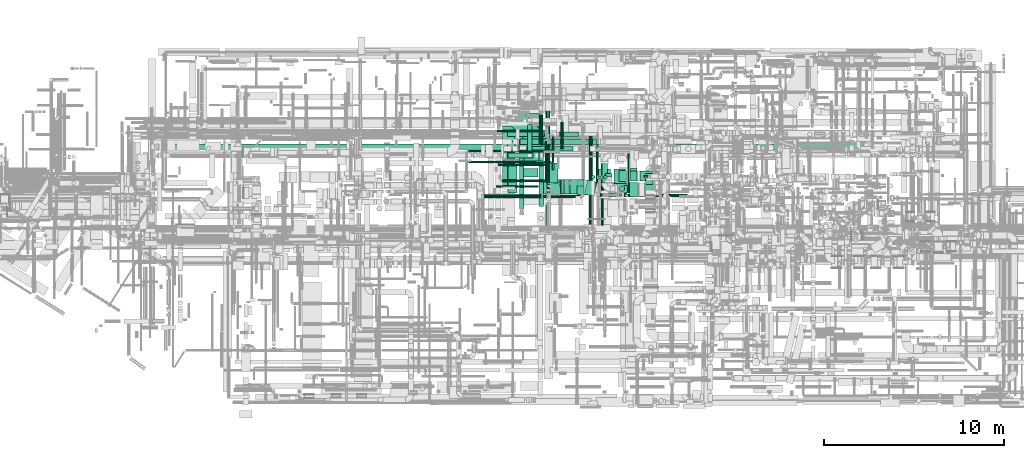
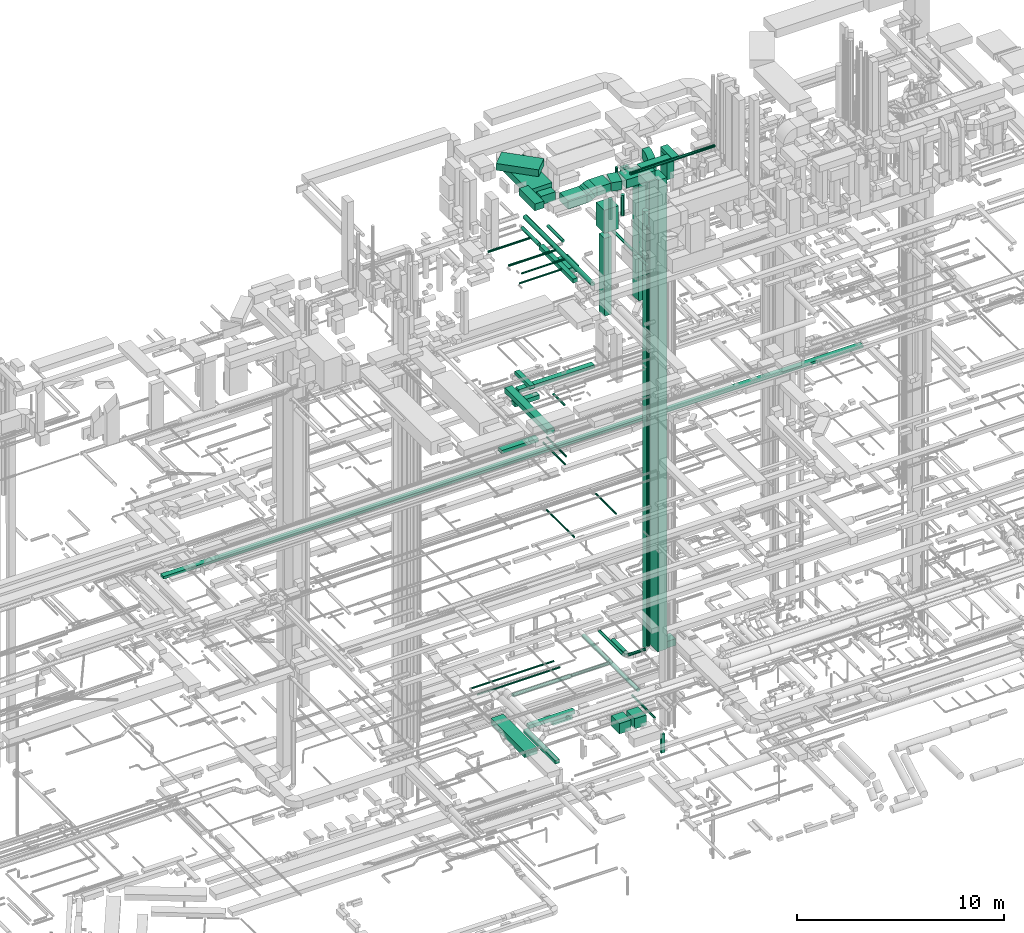
# One storey, part 42 of 337: 62 flow segments, 3 flow fittings.
"""IFC2X3 building model written with IfcOpenShell, lengths in millimetres."""

from ifc_helpers import new_model, entity, si_unit, converted_unit, derived_unit, direction, frame, frame_2d, origin, origin_2d_with_axis, place, context, subcontext, project, spatial, polyline, circle_curve, parameter, trimmed, segment, composite_curve, rectangle, circle, outline, extrude, source, transform, mapped, material, type_object, type_shapes, element, save


model = new_model("IFC2X3")

# Units and contexts
model_context = context("Model", 3, precision=0.01, world=origin(), true_north=direction((6.12303176911189e-17, 1.0)))
body_context = subcontext(model_context, "Body", "Model", "MODEL_VIEW")
ifc_project = project(units=[si_unit("LENGTHUNIT", "METRE", prefix="MILLI"), si_unit("AREAUNIT", "SQUARE_METRE"), si_unit("VOLUMEUNIT", "CUBIC_METRE"), converted_unit("PLANEANGLEUNIT", "DEGREE", entity("IfcRatioMeasure", 0.0174532925199433), si_unit("PLANEANGLEUNIT", "RADIAN"), dimensions=[0, 0, 0, 0, 0, 0, 0]), si_unit("MASSUNIT", "GRAM", prefix="KILO"), derived_unit("MASSDENSITYUNIT", [(si_unit("MASSUNIT", "GRAM", prefix="KILO"), 1), (si_unit("LENGTHUNIT", "METRE"), -3)]), derived_unit("MOMENTOFINERTIAUNIT", [(si_unit("LENGTHUNIT", "METRE"), 4)]), si_unit("TIMEUNIT", "SECOND"), si_unit("FREQUENCYUNIT", "HERTZ"), si_unit("THERMODYNAMICTEMPERATUREUNIT", "DEGREE_CELSIUS"), derived_unit("THERMALTRANSMITTANCEUNIT", [(si_unit("MASSUNIT", "GRAM", prefix="KILO"), 1), (si_unit("THERMODYNAMICTEMPERATUREUNIT", "KELVIN"), -1), (si_unit("TIMEUNIT", "SECOND"), -3)]), derived_unit("VOLUMETRICFLOWRATEUNIT", [(si_unit("LENGTHUNIT", "METRE"), 3), (si_unit("TIMEUNIT", "SECOND"), -1)]), derived_unit("MASSFLOWRATEUNIT", [(si_unit("MASSUNIT", "GRAM", prefix="KILO"), 1), (si_unit("TIMEUNIT", "SECOND"), -1)]), derived_unit("ROTATIONALFREQUENCYUNIT", [(si_unit("TIMEUNIT", "SECOND"), -1)]), si_unit("ELECTRICCURRENTUNIT", "AMPERE"), si_unit("ELECTRICVOLTAGEUNIT", "VOLT"), si_unit("POWERUNIT", "WATT"), si_unit("FORCEUNIT", "NEWTON", prefix="KILO"), si_unit("ILLUMINANCEUNIT", "LUX"), si_unit("LUMINOUSFLUXUNIT", "LUMEN"), si_unit("LUMINOUSINTENSITYUNIT", "CANDELA"), derived_unit("USERDEFINED", [(si_unit("MASSUNIT", "GRAM", prefix="KILO"), -1), (si_unit("LENGTHUNIT", "METRE"), -2), (si_unit("TIMEUNIT", "SECOND"), 3), (si_unit("LUMINOUSFLUXUNIT", "LUMEN"), 1)]), derived_unit("LINEARVELOCITYUNIT", [(si_unit("LENGTHUNIT", "METRE"), 1), (si_unit("TIMEUNIT", "SECOND"), -1)]), si_unit("PRESSUREUNIT", "PASCAL"), derived_unit("USERDEFINED", [(si_unit("LENGTHUNIT", "METRE"), -2), (si_unit("MASSUNIT", "GRAM", prefix="KILO"), 1), (si_unit("TIMEUNIT", "SECOND"), -2)]), derived_unit("LINEARFORCEUNIT", [(si_unit("MASSUNIT", "GRAM", prefix="KILO"), 1), (si_unit("LENGTHUNIT", "METRE"), 1), (si_unit("TIMEUNIT", "SECOND"), -2), (si_unit("LENGTHUNIT", "METRE"), -1)]), derived_unit("PLANARFORCEUNIT", [(si_unit("MASSUNIT", "GRAM", prefix="KILO"), 1), (si_unit("LENGTHUNIT", "METRE"), 1), (si_unit("TIMEUNIT", "SECOND"), -2), (si_unit("LENGTHUNIT", "METRE"), -2)])], contexts=[model_context])

# Site, building, storey
site_placement = place(None, origin())
site = spatial("IfcSite", under=ifc_project, at=site_placement, CompositionType="ELEMENT")
building_placement = place(site_placement, origin())
building = spatial("IfcBuilding", under=site, at=building_placement, CompositionType="ELEMENT")
storey_placement = place(building_placement, origin())
storey = spatial("IfcBuildingStorey", under=building, at=storey_placement, CompositionType="ELEMENT", Elevation=0.0)

# Flow segments
duct_segment_type_1 = type_object("IfcDuctSegmentType", PredefinedType="NOTDEFINED")
flow_segment_1_placement = place(storey_placement, frame((41093.26, 15223.96, -1725.0)))
element("IfcFlowSegment", 1, at=flow_segment_1_placement, inside=storey, type_object=duct_segment_type_1, context=body_context, shape_type="SweptSolid", body=[
    extrude(rectangle(XDim=1076.73742349618, YDim=249.999999999999, at=origin_2d_with_axis()), frame((538.37, 125.0, 0.0)), (0.0, 0.0, 1.0), 250.0),
])
flow_segment_2_placement = place(storey_placement, frame((37959.51, 12520.62, -875.0)))
element("IfcFlowSegment", 2, at=flow_segment_2_placement, inside=storey, type_object=duct_segment_type_1, context=body_context, shape_type="SweptSolid", body=[
    extrude(rectangle(XDim=3278.30706856473, YDim=700.000000000001, at=origin_2d_with_axis()), frame((350.0, 1639.15, 0.0), z_axis=(0.0, 0.0, 1.0), x_axis=(0.0, 1.0, 0.0)), (0.0, 0.0, 1.0), 350.0),
])
flow_segment_3_placement = place(storey_placement, frame((43282.27, 12621.62, -1400.0)))
element("IfcFlowSegment", 3, at=flow_segment_3_placement, inside=storey, type_object=duct_segment_type_1, context=body_context, shape_type="SweptSolid", body=[
    extrude(rectangle(XDim=803.709560000028, YDim=650.0, at=origin_2d_with_axis()), frame((325.0, 401.85, 0.0), z_axis=(0.0, 0.0, 1.0), x_axis=(0.0, 1.0, 0.0)), (0.0, 0.0, 1.0), 600.0),
])
flow_segment_4_placement = place(storey_placement, frame((44132.27, 12621.62, -1400.0)))
element("IfcFlowSegment", 4, at=flow_segment_4_placement, inside=storey, type_object=duct_segment_type_1, context=body_context, shape_type="SweptSolid", body=[
    extrude(rectangle(XDim=803.70955800005, YDim=650.0, at=origin_2d_with_axis()), frame((325.0, 401.85, 0.0), z_axis=(0.0, 0.0, 1.0), x_axis=(0.0, 1.0, 0.0)), (0.0, 0.0, 1.0), 600.0),
])
flow_segment_5_placement = place(storey_placement, frame((45814.19, 12970.83, -3640.0)))
element("IfcFlowSegment", 5, at=flow_segment_5_placement, inside=storey, type_object=duct_segment_type_1, context=body_context, shape_type="SweptSolid", body=[
    extrude(rectangle(XDim=100.000000000001, YDim=199.999999999998, at=origin_2d_with_axis()), frame((100.0, 50.0, 0.0), z_axis=(0.0, 0.0, 1.0), x_axis=(0.0, 1.0, 0.0)), (0.0, 0.0, 1.0), 1099.99999999994),
])
flow_segment_6_placement = place(storey_placement, frame((39296.44, 14423.39, -800.0)))
element("IfcFlowSegment", 6, at=flow_segment_6_placement, inside=storey, type_object=duct_segment_type_1, context=body_context, shape_type="SweptSolid", body=[
    extrude(rectangle(XDim=2568.09134999994, YDim=249.999999999999, at=origin_2d_with_axis()), frame((1284.05, 125.0, 0.0), z_axis=(0.0, 0.0, 1.0), x_axis=(-1.0, 0.0, 0.0)), (0.0, 0.0, 1.0), 200.0),
])
flow_segment_7_placement = place(storey_placement, frame((38896.44, 11223.03, -800.0)))
element("IfcFlowSegment", 7, at=flow_segment_7_placement, inside=storey, type_object=duct_segment_type_1, context=body_context, shape_type="SweptSolid", body=[
    extrude(rectangle(XDim=3050.36155500002, YDim=249.999999999999, at=origin_2d_with_axis()), frame((125.0, 1525.18, 0.0), z_axis=(0.0, 0.0, 1.0), x_axis=(0.0, -1.0, 0.0)), (0.0, 0.0, 1.0), 200.0),
])
flow_segment_8_placement = place(storey_placement, frame((38241.96, 15240.0, 15250.0)))
element("IfcFlowSegment", 8, at=flow_segment_8_placement, inside=storey, type_object=duct_segment_type_1, context=body_context, shape_type="SweptSolid", body=[
    extrude(rectangle(XDim=2056.07386581395, YDim=350.000000000001, at=origin_2d_with_axis()), frame((1028.04, 175.0, 0.0)), (0.0, 0.0, 1.0), 199.999999999998),
])
flow_segment_9_placement = place(storey_placement, frame((44995.05, 11889.6, 3271.64)))
element("IfcFlowSegment", 9, at=flow_segment_9_placement, inside=storey, type_object=duct_segment_type_1, context=body_context, shape_type="SweptSolid", body=[
    extrude(rectangle(XDim=799.999999999998, YDim=499.999999999999, at=origin_2d_with_axis()), frame((250.0, 400.0, 0.0), z_axis=(0.0, 0.0, 1.0), x_axis=(0.0, -1.0, 0.0)), (0.0, 0.0, 1.0), 27728.3577041547),
])
flow_segment_10_placement = place(storey_placement, frame((19016.53, 14518.91, 15050.0)))
element("IfcFlowSegment", 10, at=flow_segment_10_placement, inside=storey, type_object=duct_segment_type_1, context=body_context, shape_type="SweptSolid", body=[
    extrude(rectangle(XDim=38940.7501026085, YDim=300.000000000001, at=origin_2d_with_axis()), frame((19470.38, 150.0, 0.0)), (0.0, 0.0, 1.0), 150.000000000001),
])
flow_segment_11_placement = place(storey_placement, frame((38248.74, 10859.26, 19025.0)))
element("IfcFlowSegment", 11, at=flow_segment_11_placement, inside=storey, type_object=duct_segment_type_1, context=body_context, shape_type="SweptSolid", body=[
    extrude(rectangle(XDim=4100.73593128811, YDim=400.0, at=origin_2d_with_axis()), frame((200.0, 2050.37, 0.0), z_axis=(0.0, 0.0, 1.0), x_axis=(0.0, -1.0, 0.0)), (0.0, 0.0, 1.0), 300.000000000001),
])
flow_segment_12_placement = place(storey_placement, frame((38273.73, 14025.53, 18725.0)))
element("IfcFlowSegment", 12, at=flow_segment_12_placement, inside=storey, type_object=duct_segment_type_1, context=body_context, shape_type="SweptSolid", body=[
    extrude(rectangle(XDim=1374.33837842056, YDim=299.999999999999, at=origin_2d_with_axis()), frame((687.17, 150.0, 0.0)), (0.0, 0.0, 1.0), 249.999999999999),
])
flow_segment_13_placement = place(storey_placement, frame((39339.82, 14424.64, 19150.0)))
element("IfcFlowSegment", 13, at=flow_segment_13_placement, inside=storey, type_object=duct_segment_type_1, context=body_context, shape_type="SweptSolid", body=[
    extrude(rectangle(XDim=1457.07160940672, YDim=250.000000000004, at=origin_2d_with_axis()), frame((125.0, 728.54, 0.0), z_axis=(0.0, 0.0, 1.0), x_axis=(0.0, 1.0, 0.0)), (0.0, 0.0, 1.0), 200.000000000002),
])
flow_segment_14_placement = place(storey_placement, frame((38931.07, 14788.36, 18850.0)))
element("IfcFlowSegment", 14, at=flow_segment_14_placement, inside=storey, type_object=duct_segment_type_1, context=body_context, shape_type="SweptSolid", body=[
    extrude(rectangle(XDim=4232.51962920732, YDim=299.999999999999, at=origin_2d_with_axis()), frame((2116.26, 150.0, 0.0), z_axis=(0.0, 0.0, 1.0), x_axis=(-1.0, 0.0, 0.0)), (0.0, 0.0, 1.0), 200.000000000002),
])
flow_segment_15_placement = place(storey_placement, frame((44420.31, 12737.27, 23600.0)))
element("IfcFlowSegment", 15, at=flow_segment_15_placement, inside=storey, type_object=duct_segment_type_1, context=body_context, shape_type="SweptSolid", body=[
    extrude(rectangle(XDim=600.0, YDim=400.000000000004, at=origin_2d_with_axis()), frame((200.0, 300.0, 0.0), z_axis=(0.0, 0.0, 1.0), x_axis=(0.0, -1.0, 0.0)), (0.0, 0.0, 1.0), 7400.00000000026),
])
flow_segment_16_placement = place(storey_placement, frame((39970.11, 11346.34, 27045.0)))
element("IfcFlowSegment", 16, at=flow_segment_16_placement, inside=storey, type_object=duct_segment_type_1, context=body_context, shape_type="SweptSolid", body=[
    extrude(rectangle(XDim=3279.99999999988, YDim=250.000000000004, at=origin_2d_with_axis()), frame((125.0, 1640.0, 0.0), z_axis=(0.0, 0.0, 1.0), x_axis=(0.0, -1.0, 0.0)), (0.0, 0.0, 1.0), 250.000000000004),
])
flow_segment_17_placement = place(storey_placement, frame((38332.21, 14425.95, 31500.0)))
element("IfcFlowSegment", 17, at=flow_segment_17_placement, inside=storey, type_object=duct_segment_type_1, context=body_context, shape_type="SweptSolid", body=[
    extrude(rectangle(XDim=2120.92082815771, YDim=999.999999999999, at=origin_2d_with_axis()), frame((1103.41, 1103.41, 0.0), z_axis=(0.0, 0.0, 1.0), x_axis=(-0.707106781186539, 0.707106781186556, 0.0)), (0.0, 0.0, 1.0), 399.999999999995),
])
flow_segment_18_placement = place(storey_placement, frame((38270.03, 12090.3, 31450.0)))
element("IfcFlowSegment", 18, at=flow_segment_18_placement, inside=storey, type_object=duct_segment_type_1, context=body_context, shape_type="SweptSolid", body=[
    extrude(rectangle(XDim=1526.00172202283, YDim=499.999999999999, at=origin_2d_with_axis()), frame((250.0, 763.0, 0.0), z_axis=(0.0, 0.0, 1.0), x_axis=(0.0, -1.0, 0.0)), (0.0, 0.0, 1.0), 399.999999999996),
])
flow_segment_19_placement = place(storey_placement, frame((45895.05, 12574.75, 30300.0)))
element("IfcFlowSegment", 19, at=flow_segment_19_placement, inside=storey, type_object=duct_segment_type_1, context=body_context, shape_type="SweptSolid", body=[
    extrude(rectangle(XDim=399.999999999996, YDim=600.0, at=origin_2d_with_axis()), frame((200.0, 300.0, 0.0)), (0.0, 0.0, 1.0), 1379.99999999999),
])
flow_segment_20_placement = place(storey_placement, frame((38887.38, 13745.26, 31050.0)))
element("IfcFlowSegment", 20, at=flow_segment_20_placement, inside=storey, type_object=duct_segment_type_1, context=body_context, shape_type="SweptSolid", body=[
    extrude(rectangle(XDim=2749.37527091807, YDim=1300.0, at=origin_2d_with_axis()), frame((650.0, 1374.69, 0.0), z_axis=(0.0, 0.0, 1.0), x_axis=(0.0, -1.0, 0.0)), (0.0, 0.0, 1.0), 399.999999999996),
])
flow_segment_21_placement = place(storey_placement, frame((39137.38, 12989.6, 30950.0)))
element("IfcFlowSegment", 21, at=flow_segment_21_placement, inside=storey, type_object=duct_segment_type_1, context=body_context, shape_type="SweptSolid", body=[
    extrude(rectangle(XDim=455.660116918303, YDim=800.0, at=origin_2d_with_axis()), frame((400.0, 227.83, 0.0), z_axis=(0.0, 0.0, 1.0), x_axis=(0.0, 1.0, 0.0)), (0.0, 0.0, 1.0), 499.999999999999),
])
flow_segment_22_placement = place(storey_placement, frame((40087.38, 12039.6, 30950.0)))
element("IfcFlowSegment", 22, at=flow_segment_22_placement, inside=storey, type_object=duct_segment_type_1, context=body_context, shape_type="SweptSolid", body=[
    extrude(rectangle(XDim=1050.17880513134, YDim=800.0, at=origin_2d_with_axis()), frame((525.09, 400.0, 0.0), z_axis=(0.0, 0.0, 1.0), x_axis=(-1.0, 0.0, 0.0)), (0.0, 0.0, 1.0), 499.999999999999),
])
flow_segment_23_placement = place(storey_placement, frame((41698.33, 12039.6, 31150.0)))
element("IfcFlowSegment", 23, at=flow_segment_23_placement, inside=storey, type_object=duct_segment_type_1, context=body_context, shape_type="SweptSolid", body=[
    extrude(rectangle(XDim=766.986921260989, YDim=800.0, at=origin_2d_with_axis()), frame((383.49, 400.0, 0.0)), (0.0, 0.0, 1.0), 499.999999999999),
])
flow_segment_24_placement = place(storey_placement, frame((42499.06, 11913.95, 31150.0)))
element("IfcFlowSegment", 24, at=flow_segment_24_placement, inside=storey, type_object=duct_segment_type_1, context=body_context, shape_type="SweptSolid", body=[
    extrude(rectangle(XDim=541.482553256042, YDim=800.0, at=origin_2d_with_axis()), frame((353.78, 450.65, 0.0), z_axis=(0.0, 0.0, 1.0), x_axis=(0.974370064785227, -0.224951054343899, 0.0)), (0.0, 0.0, 1.0), 499.999999999999),
])
flow_segment_25_placement = place(storey_placement, frame((43240.37, 11889.6, 31150.0)))
element("IfcFlowSegment", 25, at=flow_segment_25_placement, inside=storey, type_object=duct_segment_type_1, context=body_context, shape_type="SweptSolid", body=[
    extrude(rectangle(XDim=1604.67610246481, YDim=800.0, at=origin_2d_with_axis()), frame((802.34, 400.0, 0.0), z_axis=(0.0, 0.0, 1.0), x_axis=(-1.0, 0.0, 0.0)), (0.0, 0.0, 1.0), 499.999999999999),
])
flow_segment_26_placement = place(storey_placement, frame((42080.17, 11999.85, 28847.0)))
element("IfcFlowSegment", 26, at=flow_segment_26_placement, inside=storey, type_object=duct_segment_type_1, context=body_context, shape_type="SweptSolid", body=[
    extrude(rectangle(XDim=800.000000000002, YDim=800.0, at=origin_2d_with_axis()), frame((400.0, 400.0, 0.0), z_axis=(0.0, 0.0, 1.0), x_axis=(0.0, 1.0, 0.0)), (0.0, 0.0, 1.0), 1352.99999999996),
])
flow_segment_27_placement = place(storey_placement, frame((43635.05, 12974.59, 30650.0)))
element("IfcFlowSegment", 27, at=flow_segment_27_placement, inside=storey, type_object=duct_segment_type_1, context=body_context, shape_type="SweptSolid", body=[
    extrude(rectangle(XDim=200.000000000002, YDim=399.999999999996, at=origin_2d_with_axis()), frame((200.0, 100.0, 0.0), z_axis=(0.0, 0.0, 1.0), x_axis=(0.0, 1.0, 0.0)), (0.0, 0.0, 1.0), 900.000000000012),
])
flow_segment_28_placement = place(storey_placement, frame((45572.31, 12764.41, 2600.0)))
element("IfcFlowSegment", 28, at=flow_segment_28_placement, inside=storey, type_object=duct_segment_type_1, context=body_context, shape_type="SweptSolid", body=[
    extrude(rectangle(XDim=932.909529209302, YDim=550.000000000001, at=origin_2d_with_axis()), frame((466.45, 275.0, 0.0)), (0.0, 0.0, 1.0), 400.0),
])
flow_segment_29_placement = place(storey_placement, frame((40392.62, 12647.53, 26600.0)))
element("IfcFlowSegment", 29, at=flow_segment_29_placement, inside=storey, type_object=duct_segment_type_1, context=body_context, shape_type="SweptSolid", body=[
    extrude(rectangle(XDim=1100.0, YDim=650.0, at=origin_2d_with_axis()), frame((325.0, 550.0, 0.0), z_axis=(0.0, 0.0, 1.0), x_axis=(0.0, 1.0, 0.0)), (0.0, 0.0, 1.0), 349.999999999998),
])
flow_segment_30_placement = place(storey_placement, frame((41212.56, 12039.6, 31037.08)))
element("IfcFlowSegment", 30, at=flow_segment_30_placement, inside=storey, type_object=duct_segment_type_1, context=body_context, shape_type="SweptSolid", body=[
    extrude(rectangle(XDim=499.999999999997, YDim=185.640696055741, at=frame_2d((0.0, 0.0), x_axis=(0.0, 1.0))), frame((205.38, 0.0, 262.92), z_axis=(0.0, 1.0, 0.0), x_axis=(-0.866025403784445, 0.0, -0.49999999999999)), (0.0, 0.0, 1.0), 800.0),
])
flow_segment_31_placement = place(storey_placement, frame((42080.17, 11999.85, 23962.67)))
element("IfcFlowSegment", 31, at=flow_segment_31_placement, inside=storey, type_object=duct_segment_type_1, context=body_context, shape_type="SweptSolid", body=[
    extrude(rectangle(XDim=399.999999999996, YDim=499.999999999999, at=origin_2d_with_axis()), frame((200.0, 250.0, 0.0), z_axis=(0.0, 0.0, 1.0), x_axis=(-1.0, 0.0, 0.0)), (0.0, 0.0, 1.0), 4584.32835833342),
])
flow_segment_32_placement = place(storey_placement, frame((45022.31, 12764.41, 3150.0)))
element("IfcFlowSegment", 32, at=flow_segment_32_placement, inside=storey, type_object=duct_segment_type_1, context=body_context, shape_type="SweptSolid", body=[
    extrude(rectangle(XDim=549.999999999998, YDim=399.999999999996, at=origin_2d_with_axis()), frame((200.0, 275.0, 0.0), z_axis=(0.0, 0.0, 1.0), x_axis=(0.0, -1.0, 0.0)), (0.0, 0.0, 1.0), 28049.9999999999),
])
flow_segment_33_placement = place(storey_placement, frame((44185.07, 12101.92, 31700.0)))
element("IfcFlowSegment", 33, at=flow_segment_33_placement, inside=storey, type_object=duct_segment_type_1, context=body_context, shape_type="SweptSolid", body=[
    extrude(rectangle(XDim=1689.91163917801, YDim=400.0, at=origin_2d_with_axis()), frame((844.96, 200.0, 0.0)), (0.0, 0.0, 1.0), 199.999999999998),
])
flow_segment_34_placement = place(storey_placement, frame((45894.98, 12074.75, 31700.0)))
element("IfcFlowSegment", 34, at=flow_segment_34_placement, inside=storey, type_object=duct_segment_type_1, context=body_context, shape_type="SweptSolid", body=[
    extrude(rectangle(XDim=1117.49999435977, YDim=400.000000000004, at=origin_2d_with_axis()), frame((200.0, 558.75, 0.0), z_axis=(0.0, 0.0, 1.0), x_axis=(0.0, 1.0, 0.0)), (0.0, 0.0, 1.0), 199.999999999998),
])
duct_segment_type_2 = type_object("IfcDuctSegmentType", PredefinedType="NOTDEFINED")
flow_segment_35_placement = place(storey_placement, frame((44881.05, 12086.01, -764.1)))
element("IfcFlowSegment", 35, at=flow_segment_35_placement, inside=storey, type_object=duct_segment_type_2, context=body_context, shape_type="SweptSolid", body=[
    extrude(circle(Radius=62.5, at=origin_2d_with_axis()), frame((64.1, 0.0, 64.1), z_axis=(0.0, 1.0, 0.0), x_axis=(1.0, 0.0, 0.0)), (0.0, 0.0, 1.0), 2191.2981800956),
])
flow_segment_36_placement = place(storey_placement, frame((42753.53, 10050.0, 2798.4)))
element("IfcFlowSegment", 36, at=flow_segment_36_placement, inside=storey, type_object=duct_segment_type_2, context=body_context, shape_type="SweptSolid", body=[
    extrude(circle(Radius=100.0, at=origin_2d_with_axis()), frame((101.6, 0.0, 101.6), z_axis=(0.0, 1.0, 0.0), x_axis=(1.0, 0.0, 0.0)), (0.0, 0.0, 1.0), 5292.69892382725),
])
flow_segment_37_placement = place(storey_placement, frame((43171.14, 12827.92, 11398.4)))
element("IfcFlowSegment", 37, at=flow_segment_37_placement, inside=storey, type_object=duct_segment_type_2, context=body_context, shape_type="SweptSolid", body=[
    extrude(circle(Radius=50.0, at=origin_2d_with_axis()), frame((51.6, 0.0, 51.6), z_axis=(0.0, 1.0, 0.0), x_axis=(-1.0, 0.0, 0.0)), (0.0, 0.0, 1.0), 1958.54798568233),
])
flow_segment_38_placement = place(storey_placement, frame((40710.11, 13378.82, 15298.4)))
element("IfcFlowSegment", 38, at=flow_segment_38_placement, inside=storey, type_object=duct_segment_type_2, context=body_context, shape_type="SweptSolid", body=[
    extrude(circle(Radius=50.0, at=origin_2d_with_axis()), frame((51.6, 0.0, 51.6), z_axis=(0.0, 1.0, 0.0), x_axis=(-1.0, 0.0, 0.0)), (0.0, 0.0, 1.0), 1891.1833226986),
])
flow_segment_39_placement = place(storey_placement, frame((40440.83, 12133.81, 11398.4)))
element("IfcFlowSegment", 39, at=flow_segment_39_placement, inside=storey, type_object=duct_segment_type_2, context=body_context, shape_type="SweptSolid", body=[
    extrude(circle(Radius=50.0, at=origin_2d_with_axis()), frame((51.6, 0.0, 51.6), z_axis=(0.0, 1.0, 0.0), x_axis=(1.0, 0.0, 0.0)), (0.0, 0.0, 1.0), 2652.66647630016),
])
for number, where in (
    (40, (36066.08, 14368.93, 2668.4)),
    (41, (36066.08, 13766.08, 2668.4)),
):
    element("IfcFlowSegment", number, at=place(storey_placement, frame(where)), inside=storey, type_object=duct_segment_type_2, context=body_context, shape_type="SweptSolid", body=[
        extrude(circle(Radius=50.0, at=origin_2d_with_axis()), frame((0.0, 51.6, 51.6), z_axis=(1.0, 0.0, 0.0), x_axis=(0.0, -1.0, 0.0)), (0.0, 0.0, 1.0), 4603.74999999998),
    ])
flow_segment_40_placement = place(storey_placement, frame((36918.66, 11811.05, 3448.39)))
element("IfcFlowSegment", 42, at=flow_segment_40_placement, inside=storey, type_object=duct_segment_type_2, context=body_context, shape_type="SweptSolid", body=[
    extrude(circle(Radius=100.0, at=origin_2d_with_axis()), frame((0.0, 101.6, 101.6), z_axis=(1.0, 0.0, 5.02036912931222e-06), x_axis=(0.0, 1.0, 0.0)), (0.0, 0.0, 1.0), 3218.62203436986),
])
flow_segment_41_placement = place(storey_placement, frame((40177.29, 11831.05, 3468.4)))
element("IfcFlowSegment", 43, at=flow_segment_41_placement, inside=storey, type_object=duct_segment_type_2, context=body_context, shape_type="SweptSolid", body=[
    extrude(circle(Radius=80.0, at=origin_2d_with_axis()), frame((0.0, 81.6, 81.6), z_axis=(1.0, 0.0, 0.0), x_axis=(0.0, -1.0, 0.0)), (0.0, 0.0, 1.0), 2101.87500000001),
])
flow_segment_42_placement = place(storey_placement, frame((40338.44, 12834.31, 15298.4)))
element("IfcFlowSegment", 44, at=flow_segment_42_placement, inside=storey, type_object=duct_segment_type_2, context=body_context, shape_type="SweptSolid", body=[
    extrude(circle(Radius=50.0, at=origin_2d_with_axis()), frame((51.6, 0.0, 51.6), z_axis=(0.0, 1.0, 0.0), x_axis=(-1.0, 0.0, 0.0)), (0.0, 0.0, 1.0), 2114.68569269862),
])
flow_segment_43_placement = place(storey_placement, frame((43457.09, 12653.29, 3040.9)))
element("IfcFlowSegment", 45, at=flow_segment_43_placement, inside=storey, type_object=duct_segment_type_2, context=body_context, shape_type="SweptSolid", body=[
    extrude(circle(Radius=157.5, at=origin_2d_with_axis()), frame((159.1, 0.0, 159.1), z_axis=(0.0, 1.0, 0.0), x_axis=(1.0, 0.0, 0.0)), (0.0, 0.0, 1.0), 1192.66077195085),
])
flow_segment_44_placement = place(storey_placement, frame((43370.25, 11902.28, 3518.4)))
element("IfcFlowSegment", 46, at=flow_segment_44_placement, inside=storey, type_object=duct_segment_type_2, context=body_context, shape_type="SweptSolid", body=[
    extrude(circle(Radius=80.0, at=origin_2d_with_axis()), frame((0.0, 81.6, 81.6), z_axis=(1.0, 0.0, 0.0), x_axis=(0.0, 1.0, 0.0)), (0.0, 0.0, 1.0), 985.000000000027),
])
flow_segment_45_placement = place(storey_placement, frame((43128.65, 12143.87, 3518.4)))
element("IfcFlowSegment", 47, at=flow_segment_45_placement, inside=storey, type_object=duct_segment_type_2, context=body_context, shape_type="SweptSolid", body=[
    extrude(circle(Radius=80.0, at=origin_2d_with_axis()), frame((81.6, 0.0, 81.6), z_axis=(0.0, 1.0, 0.0), x_axis=(1.0, 0.0, 0.0)), (0.0, 0.0, 1.0), 2265.00000000002),
])
flow_segment_46_placement = place(storey_placement, frame((40338.29, 12926.04, 18715.9)))
element("IfcFlowSegment", 48, at=flow_segment_46_placement, inside=storey, type_object=duct_segment_type_2, context=body_context, shape_type="SweptSolid", body=[
    extrude(circle(Radius=62.5, at=origin_2d_with_axis()), frame((64.1, 0.0, 64.1), z_axis=(0.0, 1.0, 0.0), x_axis=(-1.0, 0.0, 0.0)), (0.0, 0.0, 1.0), 1075.00000000001),
])
flow_segment_47_placement = place(storey_placement, frame((39993.51, 14826.34, 27068.4)))
element("IfcFlowSegment", 49, at=flow_segment_47_placement, inside=storey, type_object=duct_segment_type_2, context=body_context, shape_type="SweptSolid", body=[
    extrude(circle(Radius=100.0, at=origin_2d_with_axis()), frame((101.6, 0.0, 101.6), z_axis=(0.0, 1.0, 0.0), x_axis=(1.0, 0.0, 0.0)), (0.0, 0.0, 1.0), 1619.99999999999),
])
flow_segment_48_placement = place(storey_placement, frame((37657.21, 15475.99, 27105.9)))
element("IfcFlowSegment", 50, at=flow_segment_48_placement, inside=storey, type_object=duct_segment_type_2, context=body_context, shape_type="SweptSolid", body=[
    extrude(circle(Radius=62.5, at=origin_2d_with_axis()), frame((0.0, 64.1, 64.1), z_axis=(1.0, 0.0, 0.0), x_axis=(0.0, 1.0, 0.0)), (0.0, 0.0, 1.0), 2317.90000000006),
])
flow_segment_49_placement = place(storey_placement, frame((37617.21, 12403.51, 27148.4)))
element("IfcFlowSegment", 51, at=flow_segment_49_placement, inside=storey, type_object=duct_segment_type_2, context=body_context, shape_type="SweptSolid", body=[
    extrude(circle(Radius=50.0, at=origin_2d_with_axis()), frame((0.0, 51.6, 51.6), z_axis=(1.0, 0.0, 0.0), x_axis=(0.0, 1.0, 0.0)), (0.0, 0.0, 1.0), 2332.89999999999),
])
flow_segment_50_placement = place(storey_placement, frame((41184.36, 14540.86, 27068.4)))
element("IfcFlowSegment", 52, at=flow_segment_50_placement, inside=storey, type_object=duct_segment_type_2, context=body_context, shape_type="SweptSolid", body=[
    extrude(circle(Radius=80.0, at=origin_2d_with_axis()), frame((81.6, 0.0, 81.6), z_axis=(0.0, 1.0, 0.0), x_axis=(1.0, 0.0, 0.0)), (0.0, 0.0, 1.0), 1480.00000000001),
])
flow_segment_51_placement = place(storey_placement, frame((40334.03, 10302.41, 27348.4)))
element("IfcFlowSegment", 53, at=flow_segment_51_placement, inside=storey, type_object=duct_segment_type_2, context=body_context, shape_type="SweptSolid", body=[
    extrude(circle(Radius=125.0, at=origin_2d_with_axis()), frame((126.6, 0.0, 126.6), z_axis=(0.0, 1.0, 1.31620447005784e-06), x_axis=(-1.0, 0.0, 0.0)), (0.0, 0.0, 1.0), 6519.85024673468),
])
flow_segment_52_placement = place(storey_placement, frame((37715.02, 13598.43, 27410.9)))
element("IfcFlowSegment", 54, at=flow_segment_52_placement, inside=storey, type_object=duct_segment_type_2, context=body_context, shape_type="SweptSolid", body=[
    extrude(circle(Radius=62.5, at=origin_2d_with_axis()), frame((0.0, 64.1, 64.1), z_axis=(1.0, 0.0, 0.0), x_axis=(0.0, -1.0, 0.0)), (0.0, 0.0, 1.0), 2600.60030813807),
])
flow_segment_53_placement = place(storey_placement, frame((37928.89, 12730.23, 27423.4)))
element("IfcFlowSegment", 55, at=flow_segment_53_placement, inside=storey, type_object=duct_segment_type_2, context=body_context, shape_type="SweptSolid", body=[
    extrude(circle(Radius=50.0, at=origin_2d_with_axis()), frame((0.0, 51.6, 51.6), z_axis=(1.0, 0.0, 0.0), x_axis=(0.0, -1.0, 0.0)), (0.0, 0.0, 1.0), 2386.73288566012),
])
flow_segment_54_placement = place(storey_placement, frame((43407.09, 10302.41, 27468.4)))
element("IfcFlowSegment", 56, at=flow_segment_54_placement, inside=storey, type_object=duct_segment_type_2, context=body_context, shape_type="SweptSolid", body=[
    extrude(circle(Radius=80.0, at=origin_2d_with_axis()), frame((81.6, 0.0, 81.6), z_axis=(0.0, 1.0, 0.0), x_axis=(1.0, 0.0, 0.0)), (0.0, 0.0, 1.0), 3504.10479746462),
])
flow_segment_55_placement = place(storey_placement, frame((43491.04, 11872.18, 31818.4)))
element("IfcFlowSegment", 57, at=flow_segment_55_placement, inside=storey, type_object=duct_segment_type_2, context=body_context, shape_type="SweptSolid", body=[
    extrude(circle(Radius=80.0, at=origin_2d_with_axis()), frame((0.0, 81.6, 81.6), z_axis=(1.0, 0.0, 0.0), x_axis=(0.0, 1.0, 0.0)), (0.0, 0.0, 1.0), 4710.00000000001),
])
flow_segment_56_placement = place(storey_placement, frame((43254.45, 12898.0, 30319.14)))
element("IfcFlowSegment", 58, at=flow_segment_56_placement, inside=storey, type_object=duct_segment_type_2, context=body_context, shape_type="SweptSolid", body=[
    extrude(circle(Radius=75.0, at=origin_2d_with_axis()), frame((76.6, 76.6, 0.0), z_axis=(0.0, 0.0, 1.0), x_axis=(-1.0, 0.0, 0.0)), (0.0, 0.0, 1.0), 1410.85551),
])
for number, where in (
    (59, (43563.63, 12873.0, 28799.14)),
    (60, (42886.12, 12873.0, 28799.14)),
):
    element("IfcFlowSegment", number, at=place(storey_placement, frame(where)), inside=storey, type_object=duct_segment_type_2, context=body_context, shape_type="SweptSolid", body=[
        extrude(circle(Radius=100.0, at=origin_2d_with_axis()), frame((101.6, 101.6, 0.0), z_axis=(0.0, 0.0, 1.0), x_axis=(0.0, 1.0, 0.0)), (0.0, 0.0, 1.0), 1200.00000000001),
    ])
flow_segment_57_placement = place(storey_placement, frame((44414.6, 12179.19, 3515.0)))
element("IfcFlowSegment", 61, at=flow_segment_57_placement, inside=storey, type_object=duct_segment_type_2, context=body_context, shape_type="SweptSolid", body=[
    extrude(circle(Radius=157.5, at=origin_2d_with_axis()), frame((159.1, 159.1, 0.0), z_axis=(0.0, 0.0, 1.0), x_axis=(-1.0, 0.0, 0.0)), (0.0, 0.0, 1.0), 25635.2417005293),
])
flow_segment_58_placement = place(storey_placement, frame((44433.65, 11902.28, 3760.0)))
element("IfcFlowSegment", 62, at=flow_segment_58_placement, inside=storey, type_object=duct_segment_type_2, context=body_context, shape_type="SweptSolid", body=[
    extrude(circle(Radius=80.0, at=origin_2d_with_axis()), frame((81.6, 81.6, 0.0), z_axis=(0.0, 0.0, 1.0), x_axis=(0.0, -1.0, 0.0)), (0.0, 0.0, 1.0), 24680.0),
])

# Flow fittings
ifc_material = material()
duct_fitting_type_1 = type_object("IfcDuctFittingType", PredefinedType="NOTDEFINED", material=ifc_material)
shared_shape_1 = source(origin(), body_context, "Body", "SweptSolid", [
    extrude(outline(composite_curve([segment(polyline([(-276.79, -100.0), (223.21, -100.0)]), True, "CONTINUOUS"), segment(trimmed(circle_curve(frame_2d((373.21, -100.0), x_axis=(-0.866025403784441, 0.499999999999996)), 150.0), [parameter(0.0)], [parameter(29.9999999999998)], True, "PARAMETER"), False, "CONTINUOUS"), segment(polyline([(243.3, -25.0), (-189.71, 225.0)]), True, "CONTINUOUS"), segment(trimmed(circle_curve(frame_2d((373.21, -100.0), x_axis=(-0.866025403784441, 0.499999999999996)), 650.0), [parameter(0.0)], [parameter(29.9999999999998)], True, "PARAMETER"), True, "CONTINUOUS")], self_intersect=False)), frame((-7.18, 26.79, -400.0), z_axis=(0.0, 0.0, 1.0), x_axis=(-0.499999999999997, 0.866025403784441, 0.0)), (0.0, 0.0, 1.0), 800.0),
])
type_shapes(duct_fitting_type_1, [shared_shape_1])
for number, where, z_axis, x_axis in (
    (63, (41591.15, 12439.6, 31400.0), (0.0, -1.0, 0.0), (-1.0, 0.0, 0.0)),
    (64, (41244.74, 12439.6, 31200.0), (0.0, 1.0, 0.0), (-0.866025403784438, 0.0, -0.500000000000002)),
):
    element("IfcFlowFitting", number, at=place(storey_placement, frame(where, z_axis=z_axis, x_axis=x_axis)), inside=storey, type_object=duct_fitting_type_1, material=ifc_material, context=body_context, shape_type="MappedRepresentation", body=[
        mapped(shared_shape_1, transform((0.0, 0.0, 0.0), scale=1.0)),
    ])
duct_fitting_type_2 = type_object("IfcDuctFittingType", PredefinedType="NOTDEFINED", material=ifc_material)
shared_shape_2 = source(origin(), body_context, "Body", "SweptSolid", [
    extrude(outline(composite_curve([segment(polyline([(-487.5, -212.5), (62.5, -212.5)]), True, "CONTINUOUS"), segment(trimmed(circle_curve(frame_2d((212.5, -212.5), x_axis=(0.0, 1.0)), 150.0), [parameter(0.0)], [parameter(90.0)], True, "PARAMETER"), False, "CONTINUOUS"), segment(polyline([(212.5, -62.5), (212.5, 487.5)]), True, "CONTINUOUS"), segment(trimmed(circle_curve(frame_2d((212.5, -212.5), x_axis=(0.0, 1.0)), 700.0), [parameter(0.0)], [parameter(90.0)], True, "PARAMETER"), True, "CONTINUOUS")], self_intersect=False)), frame((-212.5, 212.5, -200.0), z_axis=(0.0, 0.0, 1.0), x_axis=(-1.0, 0.0, 0.0)), (0.0, 0.0, 1.0), 400.0),
])
type_shapes(duct_fitting_type_2, [shared_shape_2])
flow_fitting_placement = place(storey_placement, frame((45222.31, 13039.41, 31625.0), z_axis=(-1.0, 0.0, 0.0), x_axis=(0.0, 0.0, 1.0)))
element("IfcFlowFitting", 65, at=flow_fitting_placement, inside=storey, type_object=duct_fitting_type_2, material=ifc_material, context=body_context, shape_type="MappedRepresentation", body=[
    mapped(shared_shape_2, transform((0.0, 0.0, 0.0), scale=1.0)),
])

save(model, "model.ifc")
